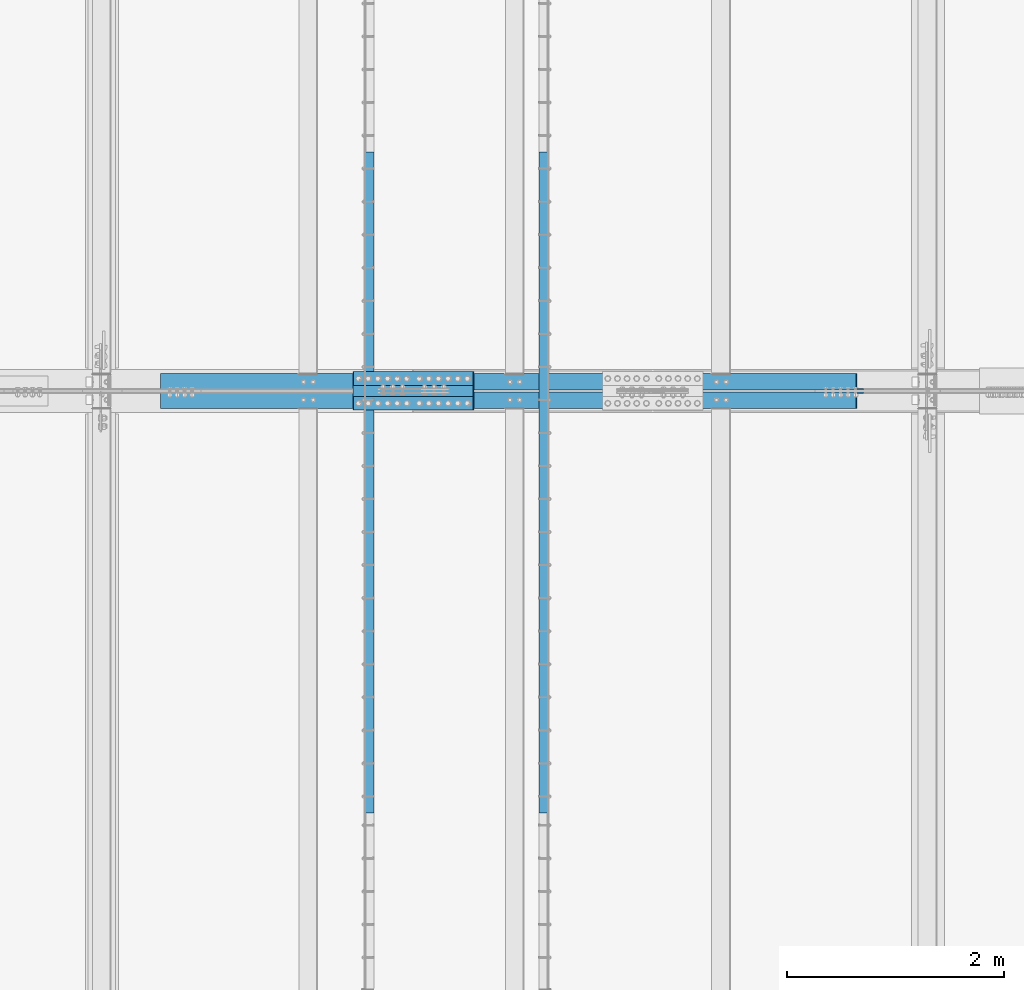
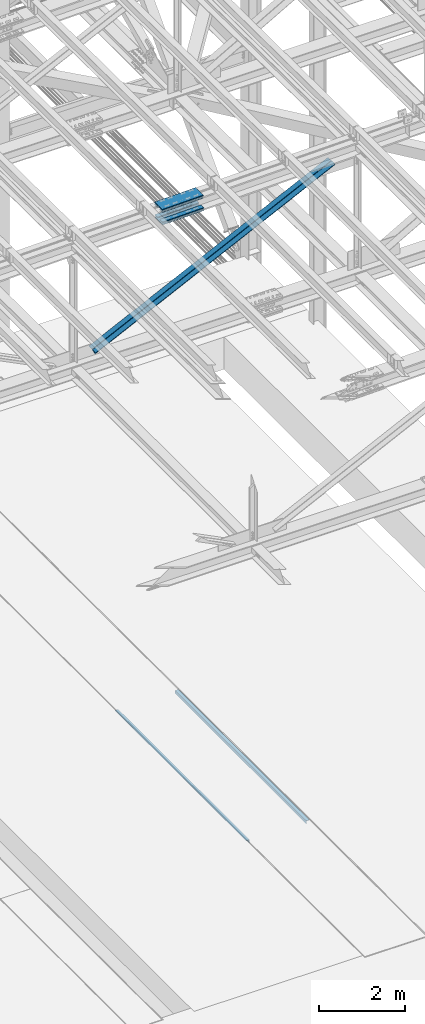
# One storey, part 1904 of 3843: 8 beams, 2 members, 5 elements without a shape of their own.
"""IFC2X3 building model written with IfcOpenShell, lengths in millimetres."""

from ifc_helpers import new_model, si_unit, frame, origin_with_axes, place, context, subcontext, project, spatial, faceted_brep, material, type_object, element, aggregate, save


model = new_model("IFC2X3")

# Units and contexts
model_context = context("Model", 3, precision=1e-05, world=origin_with_axes())
body_context = subcontext(model_context, "Body", "Model", "MODEL_VIEW")
ifc_project = project(units=[si_unit("LENGTHUNIT", "METRE", prefix="MILLI"), si_unit("AREAUNIT", "SQUARE_METRE"), si_unit("VOLUMEUNIT", "CUBIC_METRE"), si_unit("MASSUNIT", "GRAM", prefix="KILO"), si_unit("TIMEUNIT", "SECOND"), si_unit("PLANEANGLEUNIT", "RADIAN"), si_unit("SOLIDANGLEUNIT", "STERADIAN"), si_unit("THERMODYNAMICTEMPERATUREUNIT", "DEGREE_CELSIUS"), si_unit("LUMINOUSINTENSITYUNIT", "LUMEN")], contexts=[model_context])

# Site, building, storey
site_placement = place(None, origin_with_axes())
site = spatial("IfcSite", under=ifc_project, at=site_placement, CompositionType="ELEMENT")
building_placement = place(site_placement, origin_with_axes())
building = spatial("IfcBuilding", under=site, at=building_placement, Name="Undefined", CompositionType="ELEMENT")
storey_placement = place(building_placement, origin_with_axes())
storey = spatial("IfcBuildingStorey", under=building, at=storey_placement, Name="Undefined", CompositionType="ELEMENT", Elevation=0.0)

# Assembly, beam
assembly_1_placement = place(storey_placement, origin_with_axes())
assembly_1 = element("IfcElementAssembly", 1, at=assembly_1_placement, inside=storey, Name="EMBED_ANGLE", AssemblyPlace="NOTDEFINED", PredefinedType="RIGID_FRAME")
ifc_material_1 = material(Name="STEEL/A36")
beam_type_1 = type_object("IfcBeamType", Name="L3-1/2X3-1/2X5/16", PredefinedType="NOTDEFINED")
beam_1_placement = place(assembly_1_placement, frame((66713.862, 77831.822703125, 30410.15), z_axis=(0.0, 0.0, -1.0), x_axis=(0.0, -1.0, 0.0)))
beam_1 = element("IfcBeam", 2, at=beam_1_placement, type_object=beam_type_1, material=ifc_material_1, Name="EMBED_ANGLE", ObjectType="L3-1/2X3-1/2X5/16", context=body_context, shape_type="Brep", body=[
    faceted_brep([(-3.63797880709171e-12, 44.4499999999971, -44.4500000000007), (-3.63797880709171e-12, 44.4499999999971, 44.4500000000007), (6096.0, 44.4499999999971, 44.4500000000007), (6096.0, 44.4499999999971, -44.4500000000007), (-3.63797880709171e-12, 36.5124999999971, 44.4500000000007), (6096.0, 36.5124999999971, 44.4500000000007), (-3.63797880709171e-12, 36.5124999999971, -36.5125000000007), (6096.0, 36.5124999999971, -36.5125000000007), (3.63797880709171e-12, -44.4499999999971, -36.5125000000007), (6096.0, -44.4499999999971, -36.5125000000007), (3.63797880709171e-12, -44.4499999999971, -44.4500000000007), (6096.0, -44.4499999999971, -44.4500000000007)], [[[0, 1, 2, 3]], [[1, 4, 5, 2]], [[4, 6, 7, 5]], [[6, 8, 9, 7]], [[8, 10, 11, 9]], [[10, 0, 3, 11]], [[5, 7, 9, 11, 3, 2]], [[10, 8, 6, 4, 1, 0]]]),
])
aggregate(assembly_1, [beam_1])

assembly_2_placement = place(storey_placement, origin_with_axes())
assembly_2 = element("IfcElementAssembly", 3, at=assembly_2_placement, inside=storey, Name="EMBED_ANGLE", AssemblyPlace="NOTDEFINED", PredefinedType="RIGID_FRAME")
beam_2_placement = place(assembly_2_placement, frame((65101.0255556641, 71735.822703125, 30410.15), z_axis=(0.0, 0.0, -1.0), x_axis=(0.0, 1.0, 0.0)))
beam_2 = element("IfcBeam", 4, at=beam_2_placement, type_object=beam_type_1, material=ifc_material_1, Name="EMBED_ANGLE", ObjectType="L3-1/2X3-1/2X5/16", context=body_context, shape_type="Brep", body=[
    faceted_brep([(-3.63797880709171e-12, 44.4499999999971, -44.4500000000007), (-3.63797880709171e-12, 44.4499999999971, 44.4500000000007), (6096.0, 44.4499999999971, 44.4500000000007), (6096.0, 44.4499999999971, -44.4500000000007), (-3.63797880709171e-12, 36.5124999999971, 44.4500000000007), (6096.0, 36.5124999999971, 44.4500000000007), (-3.63797880709171e-12, 36.5124999999971, -36.5125000000007), (6096.0, 36.5124999999971, -36.5125000000007), (3.63797880709171e-12, -44.4499999999971, -36.5125000000007), (6096.0, -44.4499999999971, -36.5125000000007), (3.63797880709171e-12, -44.4499999999971, -44.4500000000007), (6096.0, -44.4499999999971, -44.4500000000007)], [[[0, 1, 2, 3]], [[1, 4, 5, 2]], [[4, 6, 7, 5]], [[6, 8, 9, 7]], [[8, 10, 11, 9]], [[10, 0, 3, 11]], [[5, 7, 9, 11, 3, 2]], [[10, 8, 6, 4, 1, 0]]]),
])
aggregate(assembly_2, [beam_2])

# Assembly, beams
assembly_3_placement = place(storey_placement, origin_with_axes())
assembly_3 = element("IfcElementAssembly", 5, at=assembly_3_placement, inside=storey, Name="BEAM", AssemblyPlace="NOTDEFINED", PredefinedType="RIGID_FRAME")
ifc_material_2 = material(Name="STEEL/A572-50")
beam_type_2 = type_object("IfcBeamType", PredefinedType="NOTDEFINED")
beam_3_placement = place(assembly_3_placement, frame((64955.3370474604, 75742.8, 46049.7928020946), z_axis=(0.0, -1.0, 0.0), x_axis=(0.999769188711818, 0.0, 0.0214841639938114)))
beam_3 = element("IfcBeam", 6, at=beam_3_placement, type_object=beam_type_2, material=ifc_material_2, Name="PLATE", context=body_context, shape_type="Brep", body=[
    faceted_brep([(-4.36557456851006e-11, 12.7000000000116, -63.5), (-4.36557456851006e-11, 12.7000000000116, 63.5), (1104.90000001677, 12.7000000017251, 63.5), (1104.90000001677, 12.7000000017251, -63.5), (1.45519152283669e-11, -12.700000000008, 63.5), (1104.90000001682, -12.6999999982909, 63.5), (1.45519152283669e-11, -12.700000000008, -63.5), (1104.90000001682, -12.6999999982909, -63.5)], [[[0, 1, 2, 3]], [[1, 4, 5, 2]], [[4, 6, 7, 5]], [[6, 0, 3, 7]], [[5, 7, 3, 2]], [[6, 4, 1, 0]]]),
])
beam_4_placement = place(assembly_3_placement, frame((64961.6801152087, 75742.8, 45754.6155642081), z_axis=(0.0, -1.0, 0.0), x_axis=(0.999769188711818, 0.0, 0.0214841639938114)))
beam_4 = element("IfcBeam", 7, at=beam_4_placement, type_object=beam_type_2, material=ifc_material_2, Name="PLATE", context=body_context, shape_type="Brep", body=[
    faceted_brep([(-4.36557456851006e-11, 12.7000000000116, -63.5), (-4.36557456851006e-11, 12.7000000000116, 63.5), (1104.90000001677, 12.7000000017251, 63.5), (1104.90000001677, 12.7000000017251, -63.5), (1.45519152283669e-11, -12.700000000008, 63.5), (1104.90000001682, -12.6999999982909, 63.5), (1.45519152283669e-11, -12.700000000008, -63.5), (1104.90000001682, -12.6999999982909, -63.5)], [[[0, 1, 2, 3]], [[1, 4, 5, 2]], [[4, 6, 7, 5]], [[6, 0, 3, 7]], [[5, 7, 3, 2]], [[6, 4, 1, 0]]]),
])
beam_5_placement = place(assembly_3_placement, frame((64955.3370474604, 75514.2, 46049.7928020946), z_axis=(0.0, -1.0, 0.0), x_axis=(0.999769188711818, 0.0, 0.0214841639938114)))
beam_5 = element("IfcBeam", 8, at=beam_5_placement, type_object=beam_type_2, material=ifc_material_2, Name="PLATE", context=body_context, shape_type="Brep", body=[
    faceted_brep([(-4.36557456851006e-11, 12.7000000000116, -63.5), (-4.36557456851006e-11, 12.7000000000116, 63.5), (1104.90000001677, 12.7000000017251, 63.5), (1104.90000001677, 12.7000000017251, -63.5), (1.45519152283669e-11, -12.700000000008, 63.5), (1104.90000001682, -12.6999999982909, 63.5), (1.45519152283669e-11, -12.700000000008, -63.5), (1104.90000001682, -12.6999999982909, -63.5)], [[[0, 1, 2, 3]], [[1, 4, 5, 2]], [[4, 6, 7, 5]], [[6, 0, 3, 7]], [[5, 7, 3, 2]], [[6, 4, 1, 0]]]),
])
beam_6_placement = place(assembly_3_placement, frame((64961.6801152087, 75514.2, 45754.6155642081), z_axis=(0.0, -1.0, 0.0), x_axis=(0.999769188711818, 0.0, 0.0214841639938114)))
beam_6 = element("IfcBeam", 9, at=beam_6_placement, type_object=beam_type_2, material=ifc_material_2, Name="PLATE", context=body_context, shape_type="Brep", body=[
    faceted_brep([(-4.36557456851006e-11, 12.7000000000116, -63.5), (-4.36557456851006e-11, 12.7000000000116, 63.5), (1104.90000001677, 12.7000000017251, 63.5), (1104.90000001677, 12.7000000017251, -63.5), (1.45519152283669e-11, -12.700000000008, 63.5), (1104.90000001682, -12.6999999982909, 63.5), (1.45519152283669e-11, -12.700000000008, -63.5), (1104.90000001682, -12.6999999982909, -63.5)], [[[0, 1, 2, 3]], [[1, 4, 5, 2]], [[4, 6, 7, 5]], [[6, 0, 3, 7]], [[5, 7, 3, 2]], [[6, 4, 1, 0]]]),
])
beam_type_3 = type_object("IfcBeamType", PredefinedType="NOTDEFINED")
beam_7_placement = place(assembly_3_placement, frame((66058.6498839132, 75628.5, 46135.522338789), z_axis=(0.0, -1.0, 0.0), x_axis=(-0.999769188711818, 0.0, -0.0214841639938015)))
beam_7 = element("IfcBeam", 10, at=beam_7_placement, type_object=beam_type_3, material=ifc_material_2, Name="PLATE", context=body_context, shape_type="Brep", body=[
    faceted_brep([(-1.45519152283669e-11, 12.7000000000025, -177.800000000003), (-1.45519152283669e-11, 12.7000000000025, 177.800000000003), (1104.90000001682, 12.7000000017051, 177.800000000003), (1104.90000001682, 12.7000000017051, -177.800000000003), (4.36557456851006e-11, -12.7000000000171, 177.800000000003), (1104.90000001686, -12.6999999983072, 177.800000000003), (4.36557456851006e-11, -12.7000000000171, -177.800000000003), (1104.90000001686, -12.6999999983072, -177.800000000003)], [[[0, 1, 2, 3]], [[1, 4, 5, 2]], [[4, 6, 7, 5]], [[6, 0, 3, 7]], [[5, 7, 3, 2]], [[6, 4, 1, 0]]]),
])
beam_8_placement = place(assembly_3_placement, frame((66067.6615816435, 75628.5, 45716.4255973279), z_axis=(0.0, -1.0, 0.0), x_axis=(-0.999769188711818, 0.0, -0.0214841639938015)))
beam_8 = element("IfcBeam", 11, at=beam_8_placement, type_object=beam_type_3, material=ifc_material_2, Name="PLATE", context=body_context, shape_type="Brep", body=[
    faceted_brep([(-1.45519152283669e-11, 12.7000000000025, -177.800000000003), (-1.45519152283669e-11, 12.7000000000025, 177.800000000003), (1104.90000001682, 12.7000000017051, 177.800000000003), (1104.90000001682, 12.7000000017051, -177.800000000003), (4.36557456851006e-11, -12.7000000000171, 177.800000000003), (1104.90000001686, -12.6999999983072, 177.800000000003), (4.36557456851006e-11, -12.7000000000171, -177.800000000003), (1104.90000001686, -12.6999999983072, -177.800000000003)], [[[0, 1, 2, 3]], [[1, 4, 5, 2]], [[4, 6, 7, 5]], [[6, 0, 3, 7]], [[5, 7, 3, 2]], [[6, 4, 1, 0]]]),
])
aggregate(assembly_3, [beam_3, beam_4, beam_5, beam_6, beam_7, beam_8])

# Assembly, member
assembly_4_placement = place(storey_placement, origin_with_axes())
assembly_4 = element("IfcElementAssembly", 12, at=assembly_4_placement, inside=storey, Name="ANGLE", AssemblyPlace="NOTDEFINED", PredefinedType="RIGID_FRAME")
member_type = type_object("IfcMemberType", Name="L6X6X1/2", PredefinedType="NOTDEFINED")
member_1_placement = place(assembly_4_placement, frame((70256.4, 75714.225, 46014.1431761287), z_axis=(0.0, 1.0, 0.0), x_axis=(-0.900081929817012, 0.0, -0.435720689911421)))
member_1 = element("IfcMember", 13, at=member_1_placement, type_object=member_type, material=ifc_material_2, Name="ANGLE", ObjectType="L6X6X1/2", context=body_context, shape_type="Brep", body=[
    faceted_brep([(697.56783201966, 76.2000000020325, -76.1999999999971), (697.56783201966, 76.2000000020325, 76.1999999999971), (7828.0494683615, 76.2000000234311, 76.1999999999971), (7828.0494683615, 76.2000000234311, -76.1999999999971), (697.56783201966, 63.5000000020391, 76.1999999999971), (7828.0494683615, 63.5000000234377, 76.1999999999971), (697.56783201966, 63.5000000020391, -63.5), (7828.0494683615, 63.5000000234377, -63.5), (697.567832019675, -76.1999999978379, -63.5), (7828.0494683615, -76.1999999764394, -63.5), (697.567832019675, -76.1999999978379, -76.1999999999971), (7828.0494683615, -76.1999999764394, -76.1999999999971)], [[[0, 1, 2, 3]], [[1, 4, 5, 2]], [[4, 6, 7, 5]], [[6, 8, 9, 7]], [[8, 10, 11, 9]], [[10, 0, 3, 11]], [[5, 7, 9, 11, 3, 2]], [[10, 8, 6, 4, 1, 0]]]),
])
aggregate(assembly_4, [member_1])

assembly_5_placement = place(storey_placement, origin_with_axes())
assembly_5 = element("IfcElementAssembly", 14, at=assembly_5_placement, inside=storey, Name="ANGLE", AssemblyPlace="NOTDEFINED", PredefinedType="RIGID_FRAME")
member_2_placement = place(assembly_5_placement, frame((62636.4, 75542.775, 42325.371492637), z_axis=(0.0, -1.0, 0.0), x_axis=(0.900081929817013, 0.0, 0.435720689911418)))
member_2 = element("IfcMember", 15, at=member_2_placement, type_object=member_type, material=ifc_material_2, Name="ANGLE", ObjectType="L6X6X1/2", context=body_context, shape_type="Brep", body=[
    faceted_brep([(637.848979687536, 76.199999998018, -76.1999999999971), (637.848979687536, 76.199999998018, 76.1999999999971), (7768.33061602936, 76.1999999766267, 76.1999999999971), (7768.33061602936, 76.1999999766267, -76.1999999999971), (637.848979687522, 63.4999999980282, 76.1999999999971), (7768.33061602936, 63.4999999766296, 76.1999999999971), (637.848979687522, 63.4999999980282, -63.5), (7768.33061602936, 63.4999999766296, -63.5), (637.848979687522, -76.2000000018525, -63.5), (7768.33061602936, -76.2000000232511, -63.5), (637.848979687522, -76.2000000018525, -76.1999999999971), (7768.33061602936, -76.2000000232511, -76.1999999999971)], [[[0, 1, 2, 3]], [[1, 4, 5, 2]], [[4, 6, 7, 5]], [[6, 8, 9, 7]], [[8, 10, 11, 9]], [[10, 0, 3, 11]], [[5, 7, 9, 11, 3, 2]], [[10, 8, 6, 4, 1, 0]]]),
])
aggregate(assembly_5, [member_2])

save(model, "model.ifc")
